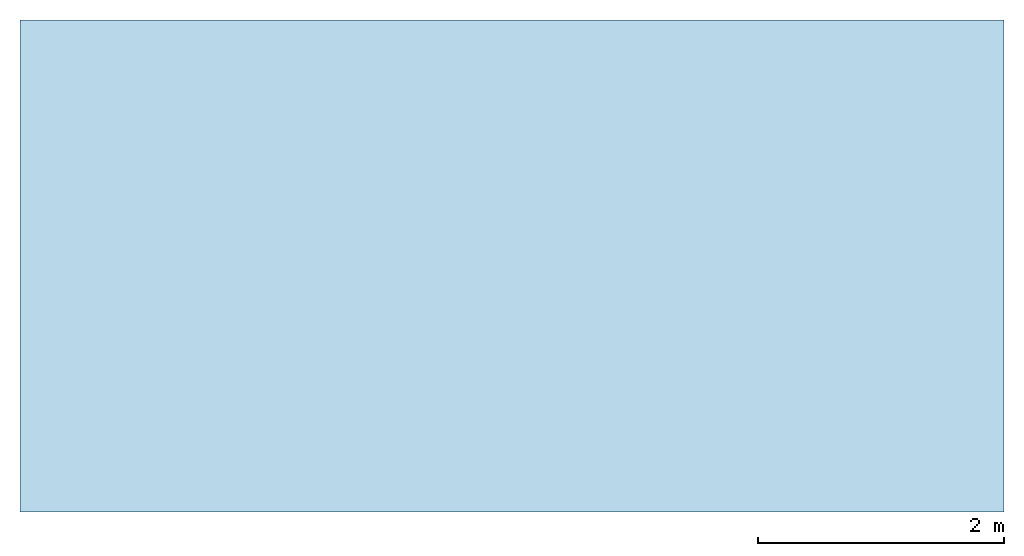
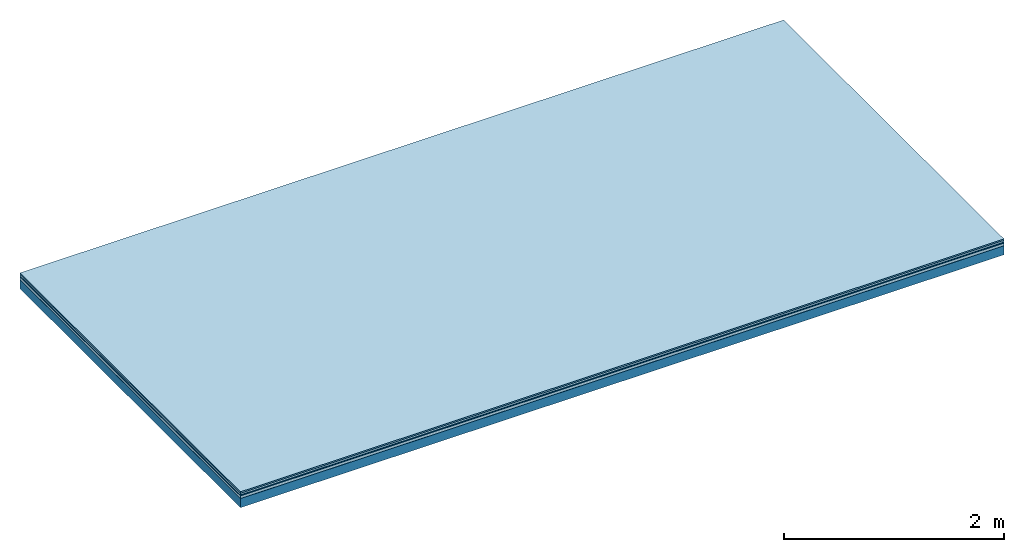
# One storey: 5 plates, 1 member, 1 element without a shape of its own.
"""IFC4 building model written with IfcOpenShell, lengths in metres."""

import ifcopenshell
import ifcopenshell.guid

model = None  # the IFC model being written
_history = None  # IfcOwnerHistory: only IFC2X3 demands one
_inside = {}  # id of a spatial element -> (the spatial element, [elements in it])
_under = {}  # id of a project, library or spatial element -> (it, [spatial elements below it])
_declared = {}  # id of a project -> (the project, [libraries it declares])
_typed = {}  # id of a type object -> (the type object, [elements of that type])
_made_of = {}  # id of a material, layer set ... -> (it, [elements and type objects made of it])


def new_model(schema):
    """Start an empty IFC model of exactly this schema.

    Asked for "IFC4X3", IfcOpenShell would pick the latest addendum, in which some entities
    have other attributes; the version numbers below select the first issue.
    IFC2X3 requires an IfcOwnerHistory on every rooted entity: one is made here for all.
    """
    global model, _history
    if schema == "IFC4X3":
        model = ifcopenshell.file(schema_version=(4, 3, 0, 0))
    else:
        model = ifcopenshell.file(schema=schema)
    _inside.clear()
    _under.clear()
    _declared.clear()
    _typed.clear()
    _made_of.clear()
    _history = None
    if model.schema == "IFC2X3":
        org = make("IfcOrganization", Name="unknown")
        user = make(
            "IfcPersonAndOrganization",
            ThePerson=make("IfcPerson", FamilyName="unknown"),
            TheOrganization=org,
        )
        app = make(
            "IfcApplication",
            ApplicationDeveloper=org,
            Version="unknown",
            ApplicationFullName="unknown",
            ApplicationIdentifier="unknown",
        )
        _history = make(
            "IfcOwnerHistory",
            OwningUser=user,
            OwningApplication=app,
            ChangeAction="ADDED",
            CreationDate=0,
        )
    return model


def make(cls, **values):
    """One entity of the class cls with the attributes given. An attribute that is None is left unset."""
    return model.create_entity(
        cls, **{name: value for name, value in values.items() if value is not None}
    )


def rooted(cls, **values):
    """An entity with a GlobalId (a new one), such as an element, a storey or a relation."""
    return make(cls, GlobalId=ifcopenshell.guid.new(), OwnerHistory=_history, **values)


def si_unit(unit_type, name, prefix=None):
    """IfcSIUnit, for example si_unit("LENGTHUNIT", "METRE", prefix="MILLI")."""
    return make("IfcSIUnit", UnitType=unit_type, Prefix=prefix, Name=name)


def derived_unit(unit_type, elements):
    """IfcDerivedUnit: a product of units, each with its exponent."""
    return make(
        "IfcDerivedUnit",
        Elements=[
            make("IfcDerivedUnitElement", Unit=unit, Exponent=power)
            for unit, power in elements
        ],
        UnitType=unit_type,
    )


def assignment(units):
    """IfcUnitAssignment: the units of a project."""
    return None if units is None else make("IfcUnitAssignment", Units=units)


def point(xyz):
    """IfcCartesianPoint."""
    return None if xyz is None else make("IfcCartesianPoint", Coordinates=xyz)


def direction(xyz):
    """IfcDirection."""
    return None if xyz is None else make("IfcDirection", DirectionRatios=xyz)


def frame(location, z_axis=None, x_axis=None):
    """IfcAxis2Placement3D, a coordinate frame: its origin and axes. An axis left out is left unset."""
    return make(
        "IfcAxis2Placement3D",
        Location=point(location),
        Axis=direction(z_axis),
        RefDirection=direction(x_axis),
    )


def frame_2d(location, x_axis=None):
    """IfcAxis2Placement2D, a coordinate frame in the plane: its origin and x axis."""
    return make(
        "IfcAxis2Placement2D", Location=point(location), RefDirection=direction(x_axis)
    )


def origin():
    """The frame at (0, 0, 0) with its axes left unset."""
    return frame((0.0, 0.0, 0.0))


def origin_with_axes():
    """The frame at (0, 0, 0) with the z axis (0, 0, 1) and the x axis (1, 0, 0) written out."""
    return frame((0.0, 0.0, 0.0), z_axis=(0.0, 0.0, 1.0), x_axis=(1.0, 0.0, 0.0))


def place(relative_to, where):
    """IfcLocalPlacement: puts the frame where relative to a parent placement (None: the world)."""
    return make(
        "IfcLocalPlacement", PlacementRelTo=relative_to, RelativePlacement=where
    )


def context(
    kind, dimensions, precision=None, world=None, true_north=None, identifier=None
):
    """IfcGeometricRepresentationContext, for example the 3D "Model" context."""
    return make(
        "IfcGeometricRepresentationContext",
        ContextIdentifier=identifier,
        ContextType=kind,
        CoordinateSpaceDimension=dimensions,
        Precision=precision,
        WorldCoordinateSystem=world,
        TrueNorth=true_north,
    )


def project(units=None, contexts=None):
    """IfcProject with its units and contexts."""
    return rooted(
        "IfcProject",
        Name="project",
        RepresentationContexts=contexts,
        UnitsInContext=assignment(units),
    )


def spatial(cls, under=None, at=None, **own):
    """A site, building, storey or space (cls), placed at a placement, below another one or the project."""
    s = rooted(cls, ObjectPlacement=at, **own)
    if under is not None:
        _under.setdefault(under.id(), (under, []))[1].append(s)
    return s


def profile(cls, at=None, kind="AREA", **sizes):
    """A parametric profile (cls). Its sizes go by their IFC names, for example OverallWidth=200.0."""
    return make(cls, ProfileType=kind, Position=at, **sizes)


def rectangle(**sizes):
    """IfcRectangleProfileDef."""
    return profile("IfcRectangleProfileDef", **sizes)


def extrude(swept, where, along, depth):
    """IfcExtrudedAreaSolid: the profile swept, set in the frame where, extruded along a direction by depth."""
    return make(
        "IfcExtrudedAreaSolid",
        SweptArea=swept,
        Position=where,
        ExtrudedDirection=direction(along),
        Depth=depth,
    )


def shape(context_of_items, identifier, shape_type, items):
    """IfcShapeRepresentation: the items that make up one representation, for example the "Body"."""
    return make(
        "IfcShapeRepresentation",
        ContextOfItems=context_of_items,
        RepresentationIdentifier=identifier,
        RepresentationType=shape_type,
        Items=items,
    )


def material(Name=None, Category=None):
    """IfcMaterial."""
    return make("IfcMaterial", Name=Name, Category=Category)


def layer(
    of_material, thickness, ventilated=None, Name=None, Category=None, Priority=None
):
    """IfcMaterialLayer: one layer of a wall or slab, of a material (None: an air gap)."""
    return make(
        "IfcMaterialLayer",
        Material=of_material,
        LayerThickness=thickness,
        IsVentilated=ventilated,
        Name=Name,
        Category=Category,
        Priority=Priority,
    )


def layer_set(layers, Name=None):
    """IfcMaterialLayerSet."""
    return make("IfcMaterialLayerSet", MaterialLayers=layers, LayerSetName=Name)


def made_of(thing, what):
    """Note that an element or type object is made of a material, layer set ...; save() writes the relation."""
    if what is not None:
        _made_of.setdefault(what.id(), (what, []))[1].append(thing)
    return thing


def type_object(cls, material=None, **own):
    """A type object (cls), such as IfcWallType, which elements share."""
    return made_of(rooted(cls, **own), material)


def element(
    cls,
    number,
    at=None,
    inside=None,
    cuts=None,
    type_object=None,
    material=None,
    context=None,
    identifier="Body",
    shape_type=None,
    held_by="IfcProductDefinitionShape",
    body=None,
    shapes=None,
    **own,
):
    """One element of the class cls, such as IfcWall. Its Tag is "e" and its number.

    at: its placement. inside: the storey or other place that contains it. cuts: it is an
    opening in that element (IfcRelVoidsElement). A single representation is given by context,
    identifier, shape_type and body (its items); several are given by shapes. held_by: the class
    of the entity that holds the representations. save() writes the other relations.
    """
    e = rooted(cls, Tag="e%d" % number, ObjectPlacement=at, **own)
    if body is not None:
        shapes = [shape(context, identifier, shape_type, body)]
    if shapes is not None:
        e.Representation = make(held_by, Representations=shapes)
    if inside is not None:
        _inside.setdefault(inside.id(), (inside, []))[1].append(e)
    if cuts is not None:
        rooted(
            "IfcRelVoidsElement", RelatingBuildingElement=cuts, RelatedOpeningElement=e
        )
    if type_object is not None:
        _typed.setdefault(type_object.id(), (type_object, []))[1].append(e)
    return made_of(e, material)


def aggregate(whole, parts):
    """IfcRelAggregates: a whole, such as a stair, and the parts it consists of."""
    return rooted("IfcRelAggregates", RelatingObject=whole, RelatedObjects=parts)


def save(model, path):
    """Write the relations noted so far, then the file.

    IfcRelAggregates (storeys below a building ...), IfcRelContainedInSpatialStructure (elements
    in a storey), IfcRelDefinesByType, IfcRelAssociatesMaterial and IfcRelDeclares: one each for
    every whole, place, type object, material and project.
    """
    for whole, parts in _under.values():
        aggregate(whole, parts)
    for where, things in _inside.values():
        rooted(
            "IfcRelContainedInSpatialStructure",
            RelatedElements=things,
            RelatingStructure=where,
        )
    for kind, things in _typed.values():
        rooted("IfcRelDefinesByType", RelatedObjects=things, RelatingType=kind)
    for what, things in _made_of.values():
        rooted("IfcRelAssociatesMaterial", RelatedObjects=things, RelatingMaterial=what)
    for by, libraries in _declared.values():
        rooted("IfcRelDeclares", RelatingContext=by, RelatedDefinitions=libraries)
    model.write(path)


model = new_model("IFC4")

# Units and contexts
plan_context = context("Plan", 3, precision=1e-05, world=origin(), true_north=direction((0.0, 1.0)))
model_context = context("Model", 3, precision=1e-05, world=origin(), true_north=direction((0.0, 1.0)))
ifc_project = project(units=[si_unit("LENGTHUNIT", "METRE"), derived_unit("SOUNDPRESSUREUNIT", [(si_unit("PRESSUREUNIT", "PASCAL", prefix="MICRO"), 0)]), si_unit("ENERGYUNIT", "JOULE", prefix="MEGA"), si_unit("MASSUNIT", "GRAM", prefix="KILO"), derived_unit("THERMALTRANSMITTANCEUNIT", [(si_unit("POWERUNIT", "WATT"), 1), (si_unit("AREAUNIT", "SQUARE_METRE"), -1), (si_unit("THERMODYNAMICTEMPERATUREUNIT", "KELVIN"), -1)]), derived_unit("AREADENSITYUNIT", [(si_unit("MASSUNIT", "GRAM", prefix="KILO"), 1), (si_unit("AREAUNIT", "SQUARE_METRE"), -1)]), derived_unit("USERDEFINED", [(si_unit("ENERGYUNIT", "JOULE", prefix="MEGA"), 1), (si_unit("AREAUNIT", "SQUARE_METRE"), -1)])], contexts=[plan_context, model_context])

# Site, building, storey
site = spatial("IfcSite", under=ifc_project)
building_placement = place(None, origin())
building = spatial("IfcBuilding", under=site, at=building_placement)
storey_placement = place(building_placement, origin())
storey = spatial("IfcBuildingStorey", under=building, at=storey_placement)

# Slab, member, plates
ifc_material_1 = material(Category="11.013")
ifc_layer_1 = layer(ifc_material_1, 0.015, Name="Flooring")
ifc_material_2 = material(Category="03.007")
ifc_layer_2 = layer(ifc_material_2, 0.02, Name="On-material")
ifc_material_3 = material(Name="Wood fiber generic product", Category="10.009")
ifc_layer_3 = layer(ifc_material_3, 0.01, Name="Impact sound insulation")
ifc_material_4 = material(Name="with broken")
ifc_layer_4 = layer(ifc_material_4, 0.03, Name="on Supporting structure")
ifc_material_5 = material(Name="protection", Category="09.007")
ifc_layer_5 = layer(ifc_material_5, 0.0005, Name="Sub-floor")
ifc_material_6 = material(Name="no composite action")
ifc_layer_6 = layer(ifc_material_6, 0.0, Name="Bond")
ifc_layer_7 = layer(None, 0.1, Name="Supporting structure")
ifc_layer_set = layer_set([ifc_layer_1, ifc_layer_2, ifc_layer_3, ifc_layer_4, ifc_layer_5, ifc_layer_6, ifc_layer_7])
slab_type = type_object("IfcSlabType", Name="A2041", PredefinedType="NOTDEFINED", material=ifc_layer_set)
slab_placement = place(None, frame((0.0, 0.0, 0.0), z_axis=(0.0, 0.0, -1.0), x_axis=(1.0, 0.0, 0.0)))
slab = element("IfcSlab", 1, at=slab_placement, inside=storey, type_object=slab_type, material=ifc_layer_set, Name="Slab #1")
ifc_material_7 = material(Name="Solid timber panel")
member_placement = place(slab_placement, origin())
member = element("IfcMember", 2, at=member_placement, material=ifc_material_7, Name="Supporting structure", context=plan_context, shape_type="SweptSolid", body=[
    extrude(rectangle(XDim=1.0, YDim=0.1, at=frame_2d((0.5, 0.05), x_axis=(1.0, 0.0))), frame((0.0, 4.0, 0.0755), z_axis=(0.0, -1.0, 0.0), x_axis=(1.0, 0.0, 0.0)), (0.0, 0.0, 1.0), 4.0),
    extrude(rectangle(XDim=1.0, YDim=0.1, at=frame_2d((0.5, 0.05), x_axis=(1.0, 0.0))), frame((1.0, 4.0, 0.0755), z_axis=(0.0, -1.0, 0.0), x_axis=(1.0, 0.0, 0.0)), (0.0, 0.0, 1.0), 4.0),
    extrude(rectangle(XDim=1.0, YDim=0.1, at=frame_2d((0.5, 0.05), x_axis=(1.0, 0.0))), frame((2.0, 4.0, 0.0755), z_axis=(0.0, -1.0, 0.0), x_axis=(1.0, 0.0, 0.0)), (0.0, 0.0, 1.0), 4.0),
    extrude(rectangle(XDim=1.0, YDim=0.1, at=frame_2d((0.5, 0.05), x_axis=(1.0, 0.0))), frame((3.0, 4.0, 0.0755), z_axis=(0.0, -1.0, 0.0), x_axis=(1.0, 0.0, 0.0)), (0.0, 0.0, 1.0), 4.0),
    extrude(rectangle(XDim=1.0, YDim=0.1, at=frame_2d((0.5, 0.05), x_axis=(1.0, 0.0))), frame((4.0, 4.0, 0.0755), z_axis=(0.0, -1.0, 0.0), x_axis=(1.0, 0.0, 0.0)), (0.0, 0.0, 1.0), 4.0),
    extrude(rectangle(XDim=1.0, YDim=0.1, at=frame_2d((0.5, 0.05), x_axis=(1.0, 0.0))), frame((5.0, 4.0, 0.0755), z_axis=(0.0, -1.0, 0.0), x_axis=(1.0, 0.0, 0.0)), (0.0, 0.0, 1.0), 4.0),
    extrude(rectangle(XDim=1.0, YDim=0.1, at=frame_2d((0.5, 0.05), x_axis=(1.0, 0.0))), frame((6.0, 4.0, 0.0755), z_axis=(0.0, -1.0, 0.0), x_axis=(1.0, 0.0, 0.0)), (0.0, 0.0, 1.0), 4.0),
    extrude(rectangle(XDim=1.0, YDim=0.1, at=frame_2d((0.5, 0.05), x_axis=(1.0, 0.0))), frame((7.0, 4.0, 0.0755), z_axis=(0.0, -1.0, 0.0), x_axis=(1.0, 0.0, 0.0)), (0.0, 0.0, 1.0), 4.0),
])
plate_1_placement = place(slab_placement, origin())
plate_1 = element("IfcPlate", 3, at=plate_1_placement, material=ifc_material_1, Name="Flooring", context=plan_context, shape_type="SweptSolid", body=[
    extrude(rectangle(XDim=8.0, YDim=4.0, at=frame_2d((4.0, 2.0), x_axis=(1.0, 0.0))), origin_with_axes(), (0.0, 0.0, 1.0), 0.015),
])
plate_2_placement = place(slab_placement, origin())
plate_2 = element("IfcPlate", 4, at=plate_2_placement, material=ifc_material_2, Name="On-material", context=plan_context, shape_type="SweptSolid", body=[
    extrude(rectangle(XDim=8.0, YDim=4.0, at=frame_2d((4.0, 2.0), x_axis=(1.0, 0.0))), frame((0.0, 0.0, 0.015), z_axis=(0.0, 0.0, 1.0), x_axis=(1.0, 0.0, 0.0)), (0.0, 0.0, 1.0), 0.02),
])
plate_3_placement = place(slab_placement, origin())
plate_3 = element("IfcPlate", 5, at=plate_3_placement, material=ifc_material_3, Name="Impact sound insulation", context=plan_context, shape_type="SweptSolid", body=[
    extrude(rectangle(XDim=8.0, YDim=4.0, at=frame_2d((4.0, 2.0), x_axis=(1.0, 0.0))), frame((0.0, 0.0, 0.035), z_axis=(0.0, 0.0, 1.0), x_axis=(1.0, 0.0, 0.0)), (0.0, 0.0, 1.0), 0.01),
])
plate_4_placement = place(slab_placement, origin())
plate_4 = element("IfcPlate", 6, at=plate_4_placement, material=ifc_material_4, Name="on Supporting structure", context=plan_context, shape_type="SweptSolid", body=[
    extrude(rectangle(XDim=8.0, YDim=4.0, at=frame_2d((4.0, 2.0), x_axis=(1.0, 0.0))), frame((0.0, 0.0, 0.045), z_axis=(0.0, 0.0, 1.0), x_axis=(1.0, 0.0, 0.0)), (0.0, 0.0, 1.0), 0.03),
])
plate_5_placement = place(slab_placement, origin())
plate_5 = element("IfcPlate", 7, at=plate_5_placement, material=ifc_material_5, Name="Sub-floor", context=plan_context, shape_type="SweptSolid", body=[
    extrude(rectangle(XDim=8.0, YDim=4.0, at=frame_2d((4.0, 2.0), x_axis=(1.0, 0.0))), frame((0.0, 0.0, 0.075), z_axis=(0.0, 0.0, 1.0), x_axis=(1.0, 0.0, 0.0)), (0.0, 0.0, 1.0), 0.0005),
])
aggregate(slab, [plate_1, plate_2, plate_3, plate_4, plate_5, member])

save(model, "model.ifc")
